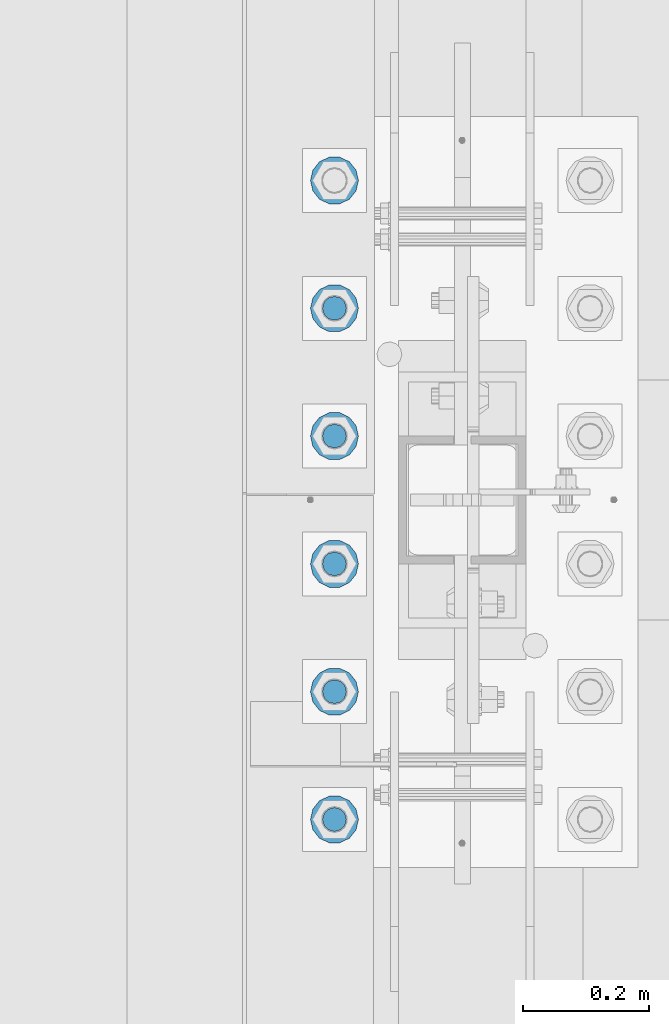
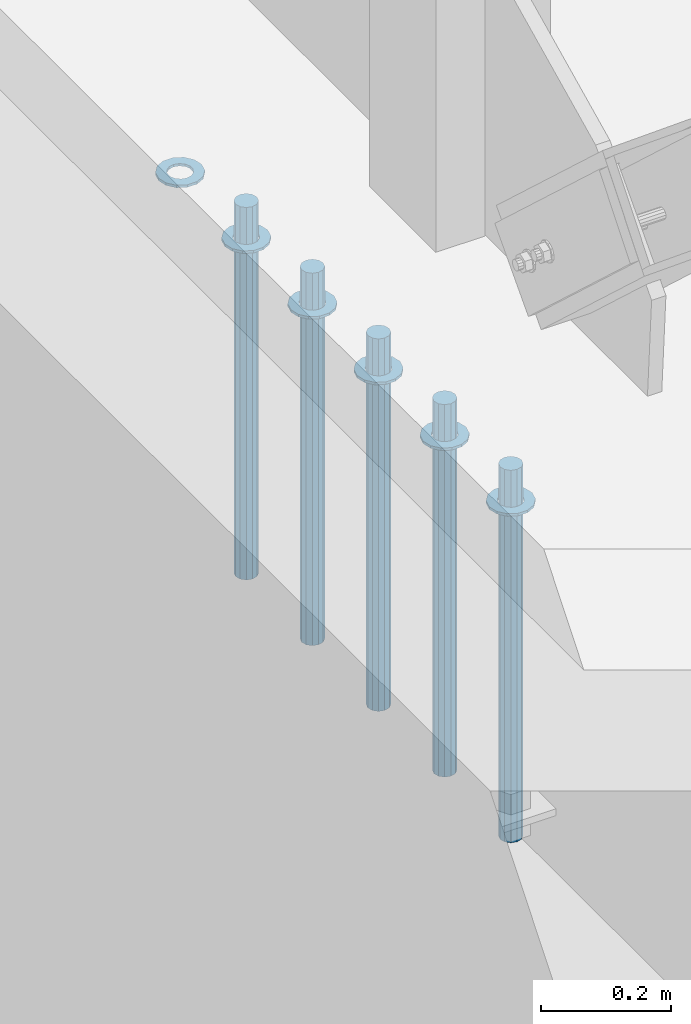
# One storey, part 923 of 1763: 11 columns, 1 element without a shape of its own.
"""IFC2X3 building model written with IfcOpenShell, lengths in millimetres."""

from ifc_helpers import new_model, si_unit, frame, origin_with_axes, place, context, subcontext, project, spatial, faceted_brep, material, type_object, element, aggregate, save


model = new_model("IFC2X3")

# Units and contexts
model_context = context("Model", 3, precision=1e-05, world=origin_with_axes())
body_context = subcontext(model_context, "Body", "Model", "MODEL_VIEW")
ifc_project = project(units=[si_unit("LENGTHUNIT", "METRE", prefix="MILLI"), si_unit("AREAUNIT", "SQUARE_METRE"), si_unit("VOLUMEUNIT", "CUBIC_METRE"), si_unit("MASSUNIT", "GRAM", prefix="KILO"), si_unit("TIMEUNIT", "SECOND"), si_unit("PLANEANGLEUNIT", "RADIAN"), si_unit("SOLIDANGLEUNIT", "STERADIAN"), si_unit("THERMODYNAMICTEMPERATUREUNIT", "DEGREE_CELSIUS"), si_unit("LUMINOUSINTENSITYUNIT", "LUMEN")], contexts=[model_context])

# Site, building, storey
site_placement = place(None, origin_with_axes())
site = spatial("IfcSite", under=ifc_project, at=site_placement, CompositionType="ELEMENT")
building_placement = place(site_placement, origin_with_axes())
building = spatial("IfcBuilding", under=site, at=building_placement, Name="Undefined", CompositionType="ELEMENT")
storey_placement = place(building_placement, origin_with_axes())
storey = spatial("IfcBuildingStorey", under=building, at=storey_placement, Name="Undefined", CompositionType="ELEMENT", Elevation=0.0)

# Assembly, columns
assembly_placement = place(storey_placement, origin_with_axes())
assembly = element("IfcElementAssembly", 1, at=assembly_placement, inside=storey, Name="TEMPLATE", AssemblyPlace="NOTDEFINED", PredefinedType="RIGID_FRAME")
ifc_material_1 = material(Name="STEEL/F436")
column_type_1 = type_object("IfcColumnType", Name="1-1/2_WASHER", PredefinedType="NOTDEFINED")
column_1_placement = place(assembly_placement, frame((-87578.6372736983, -50.7999999999992, 5151.4375), z_axis=(0.0, -1.0, 0.0), x_axis=(0.0, 0.0, -1.0)))
column_1 = element("IfcColumn", 2, at=column_1_placement, type_object=column_type_1, material=ifc_material_1, Name="WASHER", ObjectType="1-1/2_WASHER", context=body_context, shape_type="Brep", body=[
    faceted_brep([(0.0, -38.0999984741211, 0.0), (0.0, -34.3269124923099, -16.5309697983248), (4.76249999999982, -34.3269124923099, -16.5309697983248), (4.76249999999982, -38.0999984741211, 0.0), (0.0, -23.7549604994492, -29.7877782890519), (4.76249999999982, -23.7549604994492, -29.7877782890519), (0.0, -8.47804724419257, -37.1447519665053), (4.76249999999982, -8.47804724419257, -37.1447519665053), (0.0, 8.47804724419257, -37.1447519665053), (4.76249999999982, 8.47804724419257, -37.1447519665053), (0.0, 23.7549604994492, -29.7877782890519), (4.76249999999982, 23.7549604994492, -29.7877782890519), (0.0, 34.3269124923099, -16.5309697983248), (4.76249999999982, 34.3269124923099, -16.5309697983248), (0.0, 38.0999984741211, 0.0), (4.76249999999982, 38.0999984741211, 0.0), (0.0, 34.3269124923099, 16.5309697983248), (4.76249999999982, 34.3269124923099, 16.5309697983248), (0.0, 23.7549604994492, 29.7877782890519), (4.76249999999982, 23.7549604994492, 29.7877782890519), (0.0, 8.47804724419257, 37.1447519665053), (4.76249999999982, 8.47804724419257, 37.1447519665053), (0.0, -8.47804724419257, 37.1447519665053), (4.76249999999982, -8.47804724419257, 37.1447519665053), (0.0, -23.7549604994492, 29.7877782890519), (4.76249999999982, -23.7549604994492, 29.7877782890519), (0.0, -34.3269124923099, 16.5309697983248), (4.76249999999982, -34.3269124923099, 16.5309697983248), (0.0, 0.0, 20.6399993896484), (0.0, 8.95536011056538, 18.5959968835978), (4.76249999999982, 8.95536011056538, 18.5959968835978), (4.76249999999982, 0.0, 20.6399993896484), (0.0, 16.1370013209453, 12.8688291298167), (4.76249999999982, 16.1370013209453, 12.8688291298167), (0.0, 20.1225115123816, 4.59283194104137), (4.76249999999982, 20.1225115123816, 4.59283194104137), (0.0, 20.1225115123816, -4.59283194104319), (4.76249999999982, 20.1225115123816, -4.59283194104319), (0.0, 16.1370013209453, -12.8688291298167), (4.76249999999982, 16.1370013209453, -12.8688291298167), (0.0, 8.95536011056538, -18.5959968835978), (4.76249999999982, 8.95536011056538, -18.5959968835978), (0.0, 0.0, -20.6399993896484), (4.76249999999982, 0.0, -20.6399993896484), (0.0, -8.95536011056538, -18.5959968835978), (4.76249999999982, -8.95536011056538, -18.5959968835978), (0.0, -16.1370013209453, -12.8688291298167), (4.76249999999982, -16.1370013209453, -12.8688291298167), (0.0, -20.1225115123816, -4.59283194104137), (4.76249999999982, -20.1225115123816, -4.59283194104137), (0.0, -20.1225115123816, 4.59283194104319), (4.76249999999982, -20.1225115123816, 4.59283194104319), (0.0, -16.1370013209453, 12.8688291298167), (4.76249999999982, -16.1370013209453, 12.8688291298167), (0.0, -8.95536011056538, 18.5959968835978), (4.76249999999982, -8.95536011056538, 18.5959968835978)], [[[0, 1, 2, 3]], [[1, 4, 5, 2]], [[4, 6, 7, 5]], [[6, 8, 9, 7]], [[8, 10, 11, 9]], [[10, 12, 13, 11]], [[12, 14, 15, 13]], [[14, 16, 17, 15]], [[16, 18, 19, 17]], [[18, 20, 21, 19]], [[20, 22, 23, 21]], [[22, 24, 25, 23]], [[24, 26, 27, 25]], [[26, 0, 3, 27]], [[28, 29, 30, 31]], [[29, 32, 33, 30]], [[32, 34, 35, 33]], [[34, 36, 37, 35]], [[36, 38, 39, 37]], [[38, 40, 41, 39]], [[40, 42, 43, 41]], [[42, 44, 45, 43]], [[44, 46, 47, 45]], [[46, 48, 49, 47]], [[48, 50, 51, 49]], [[50, 52, 53, 51]], [[52, 54, 55, 53]], [[54, 28, 31, 55]], [[5, 7, 9, 11, 13, 15, 17, 19, 21, 23, 25, 27, 3, 2], [33, 35, 37, 39, 41, 43, 45, 47, 49, 51, 53, 55, 31, 30]], [[26, 24, 22, 20, 18, 16, 14, 12, 10, 8, 6, 4, 1, 0], [54, 52, 50, 48, 46, 44, 42, 40, 38, 36, 34, 32, 29, 28]]]),
])
column_2_placement = place(assembly_placement, frame((-87578.6372736983, 152.400000000001, 5151.4375), z_axis=(0.0, -1.0, 0.0), x_axis=(0.0, 0.0, -1.0)))
column_2 = element("IfcColumn", 3, at=column_2_placement, type_object=column_type_1, material=ifc_material_1, Name="WASHER", ObjectType="1-1/2_WASHER", context=body_context, shape_type="Brep", body=[
    faceted_brep([(0.0, -38.0999984741211, 0.0), (0.0, -34.3269124923099, -16.5309697983248), (4.76249999999982, -34.3269124923099, -16.5309697983248), (4.76249999999982, -38.0999984741211, 0.0), (0.0, -23.7549604994492, -29.7877782890519), (4.76249999999982, -23.7549604994492, -29.7877782890519), (0.0, -8.47804724419257, -37.1447519665053), (4.76249999999982, -8.47804724419257, -37.1447519665053), (0.0, 8.47804724419257, -37.1447519665053), (4.76249999999982, 8.47804724419257, -37.1447519665053), (0.0, 23.7549604994492, -29.7877782890519), (4.76249999999982, 23.7549604994492, -29.7877782890519), (0.0, 34.3269124923099, -16.5309697983248), (4.76249999999982, 34.3269124923099, -16.5309697983248), (0.0, 38.0999984741211, 0.0), (4.76249999999982, 38.0999984741211, 0.0), (0.0, 34.3269124923099, 16.5309697983248), (4.76249999999982, 34.3269124923099, 16.5309697983248), (0.0, 23.7549604994492, 29.7877782890519), (4.76249999999982, 23.7549604994492, 29.7877782890519), (0.0, 8.47804724419257, 37.1447519665053), (4.76249999999982, 8.47804724419257, 37.1447519665053), (0.0, -8.47804724419257, 37.1447519665053), (4.76249999999982, -8.47804724419257, 37.1447519665053), (0.0, -23.7549604994492, 29.7877782890519), (4.76249999999982, -23.7549604994492, 29.7877782890519), (0.0, -34.3269124923099, 16.5309697983248), (4.76249999999982, -34.3269124923099, 16.5309697983248), (0.0, 0.0, 20.6399993896484), (0.0, 8.95536011056538, 18.5959968835978), (4.76249999999982, 8.95536011056538, 18.5959968835978), (4.76249999999982, 0.0, 20.6399993896484), (0.0, 16.1370013209453, 12.8688291298167), (4.76249999999982, 16.1370013209453, 12.8688291298167), (0.0, 20.1225115123816, 4.59283194104137), (4.76249999999982, 20.1225115123816, 4.59283194104137), (0.0, 20.1225115123816, -4.59283194104319), (4.76249999999982, 20.1225115123816, -4.59283194104319), (0.0, 16.1370013209453, -12.8688291298167), (4.76249999999982, 16.1370013209453, -12.8688291298167), (0.0, 8.95536011056538, -18.5959968835978), (4.76249999999982, 8.95536011056538, -18.5959968835978), (0.0, 0.0, -20.6399993896484), (4.76249999999982, 0.0, -20.6399993896484), (0.0, -8.95536011056538, -18.5959968835978), (4.76249999999982, -8.95536011056538, -18.5959968835978), (0.0, -16.1370013209453, -12.8688291298167), (4.76249999999982, -16.1370013209453, -12.8688291298167), (0.0, -20.1225115123816, -4.59283194104137), (4.76249999999982, -20.1225115123816, -4.59283194104137), (0.0, -20.1225115123816, 4.59283194104319), (4.76249999999982, -20.1225115123816, 4.59283194104319), (0.0, -16.1370013209453, 12.8688291298167), (4.76249999999982, -16.1370013209453, 12.8688291298167), (0.0, -8.95536011056538, 18.5959968835978), (4.76249999999982, -8.95536011056538, 18.5959968835978)], [[[0, 1, 2, 3]], [[1, 4, 5, 2]], [[4, 6, 7, 5]], [[6, 8, 9, 7]], [[8, 10, 11, 9]], [[10, 12, 13, 11]], [[12, 14, 15, 13]], [[14, 16, 17, 15]], [[16, 18, 19, 17]], [[18, 20, 21, 19]], [[20, 22, 23, 21]], [[22, 24, 25, 23]], [[24, 26, 27, 25]], [[26, 0, 3, 27]], [[28, 29, 30, 31]], [[29, 32, 33, 30]], [[32, 34, 35, 33]], [[34, 36, 37, 35]], [[36, 38, 39, 37]], [[38, 40, 41, 39]], [[40, 42, 43, 41]], [[42, 44, 45, 43]], [[44, 46, 47, 45]], [[46, 48, 49, 47]], [[48, 50, 51, 49]], [[50, 52, 53, 51]], [[52, 54, 55, 53]], [[54, 28, 31, 55]], [[5, 7, 9, 11, 13, 15, 17, 19, 21, 23, 25, 27, 3, 2], [33, 35, 37, 39, 41, 43, 45, 47, 49, 51, 53, 55, 31, 30]], [[26, 24, 22, 20, 18, 16, 14, 12, 10, 8, 6, 4, 1, 0], [54, 52, 50, 48, 46, 44, 42, 40, 38, 36, 34, 32, 29, 28]]]),
])
column_3_placement = place(assembly_placement, frame((-87578.6372736983, 355.600000000001, 5151.4375), z_axis=(0.0, -1.0, 0.0), x_axis=(0.0, 0.0, -1.0)))
column_3 = element("IfcColumn", 4, at=column_3_placement, type_object=column_type_1, material=ifc_material_1, Name="WASHER", ObjectType="1-1/2_WASHER", context=body_context, shape_type="Brep", body=[
    faceted_brep([(0.0, -38.0999984741211, 0.0), (0.0, -34.3269124923099, -16.5309697983248), (4.76249999999982, -34.3269124923099, -16.5309697983248), (4.76249999999982, -38.0999984741211, 0.0), (0.0, -23.7549604994492, -29.7877782890519), (4.76249999999982, -23.7549604994492, -29.7877782890519), (0.0, -8.47804724419257, -37.1447519665053), (4.76249999999982, -8.47804724419257, -37.1447519665053), (0.0, 8.47804724419257, -37.1447519665053), (4.76249999999982, 8.47804724419257, -37.1447519665053), (0.0, 23.7549604994492, -29.7877782890519), (4.76249999999982, 23.7549604994492, -29.7877782890519), (0.0, 34.3269124923099, -16.5309697983248), (4.76249999999982, 34.3269124923099, -16.5309697983248), (0.0, 38.0999984741211, 0.0), (4.76249999999982, 38.0999984741211, 0.0), (0.0, 34.3269124923099, 16.5309697983248), (4.76249999999982, 34.3269124923099, 16.5309697983248), (0.0, 23.7549604994492, 29.7877782890519), (4.76249999999982, 23.7549604994492, 29.7877782890519), (0.0, 8.47804724419257, 37.1447519665053), (4.76249999999982, 8.47804724419257, 37.1447519665053), (0.0, -8.47804724419257, 37.1447519665053), (4.76249999999982, -8.47804724419257, 37.1447519665053), (0.0, -23.7549604994492, 29.7877782890519), (4.76249999999982, -23.7549604994492, 29.7877782890519), (0.0, -34.3269124923099, 16.5309697983248), (4.76249999999982, -34.3269124923099, 16.5309697983248), (0.0, 0.0, 20.6399993896484), (0.0, 8.95536011056538, 18.5959968835978), (4.76249999999982, 8.95536011056538, 18.5959968835978), (4.76249999999982, 0.0, 20.6399993896484), (0.0, 16.1370013209453, 12.8688291298167), (4.76249999999982, 16.1370013209453, 12.8688291298167), (0.0, 20.1225115123816, 4.59283194104137), (4.76249999999982, 20.1225115123816, 4.59283194104137), (0.0, 20.1225115123816, -4.59283194104319), (4.76249999999982, 20.1225115123816, -4.59283194104319), (0.0, 16.1370013209453, -12.8688291298167), (4.76249999999982, 16.1370013209453, -12.8688291298167), (0.0, 8.95536011056538, -18.5959968835978), (4.76249999999982, 8.95536011056538, -18.5959968835978), (0.0, 0.0, -20.6399993896484), (4.76249999999982, 0.0, -20.6399993896484), (0.0, -8.95536011056538, -18.5959968835978), (4.76249999999982, -8.95536011056538, -18.5959968835978), (0.0, -16.1370013209453, -12.8688291298167), (4.76249999999982, -16.1370013209453, -12.8688291298167), (0.0, -20.1225115123816, -4.59283194104137), (4.76249999999982, -20.1225115123816, -4.59283194104137), (0.0, -20.1225115123816, 4.59283194104319), (4.76249999999982, -20.1225115123816, 4.59283194104319), (0.0, -16.1370013209453, 12.8688291298167), (4.76249999999982, -16.1370013209453, 12.8688291298167), (0.0, -8.95536011056538, 18.5959968835978), (4.76249999999982, -8.95536011056538, 18.5959968835978)], [[[0, 1, 2, 3]], [[1, 4, 5, 2]], [[4, 6, 7, 5]], [[6, 8, 9, 7]], [[8, 10, 11, 9]], [[10, 12, 13, 11]], [[12, 14, 15, 13]], [[14, 16, 17, 15]], [[16, 18, 19, 17]], [[18, 20, 21, 19]], [[20, 22, 23, 21]], [[22, 24, 25, 23]], [[24, 26, 27, 25]], [[26, 0, 3, 27]], [[28, 29, 30, 31]], [[29, 32, 33, 30]], [[32, 34, 35, 33]], [[34, 36, 37, 35]], [[36, 38, 39, 37]], [[38, 40, 41, 39]], [[40, 42, 43, 41]], [[42, 44, 45, 43]], [[44, 46, 47, 45]], [[46, 48, 49, 47]], [[48, 50, 51, 49]], [[50, 52, 53, 51]], [[52, 54, 55, 53]], [[54, 28, 31, 55]], [[5, 7, 9, 11, 13, 15, 17, 19, 21, 23, 25, 27, 3, 2], [33, 35, 37, 39, 41, 43, 45, 47, 49, 51, 53, 55, 31, 30]], [[26, 24, 22, 20, 18, 16, 14, 12, 10, 8, 6, 4, 1, 0], [54, 52, 50, 48, 46, 44, 42, 40, 38, 36, 34, 32, 29, 28]]]),
])
column_4_placement = place(assembly_placement, frame((-87578.6372736983, 558.800000000001, 5151.4375), z_axis=(0.0, -1.0, 0.0), x_axis=(0.0, 0.0, -1.0)))
column_4 = element("IfcColumn", 5, at=column_4_placement, type_object=column_type_1, material=ifc_material_1, Name="WASHER", ObjectType="1-1/2_WASHER", context=body_context, shape_type="Brep", body=[
    faceted_brep([(0.0, -38.0999984741211, 0.0), (0.0, -34.3269124923099, -16.5309697983248), (4.76249999999982, -34.3269124923099, -16.5309697983248), (4.76249999999982, -38.0999984741211, 0.0), (0.0, -23.7549604994492, -29.7877782890519), (4.76249999999982, -23.7549604994492, -29.7877782890519), (0.0, -8.47804724419257, -37.1447519665053), (4.76249999999982, -8.47804724419257, -37.1447519665053), (0.0, 8.47804724419257, -37.1447519665053), (4.76249999999982, 8.47804724419257, -37.1447519665053), (0.0, 23.7549604994492, -29.7877782890519), (4.76249999999982, 23.7549604994492, -29.7877782890519), (0.0, 34.3269124923099, -16.5309697983248), (4.76249999999982, 34.3269124923099, -16.5309697983248), (0.0, 38.0999984741211, 0.0), (4.76249999999982, 38.0999984741211, 0.0), (0.0, 34.3269124923099, 16.5309697983248), (4.76249999999982, 34.3269124923099, 16.5309697983248), (0.0, 23.7549604994492, 29.7877782890519), (4.76249999999982, 23.7549604994492, 29.7877782890519), (0.0, 8.47804724419257, 37.1447519665053), (4.76249999999982, 8.47804724419257, 37.1447519665053), (0.0, -8.47804724419257, 37.1447519665053), (4.76249999999982, -8.47804724419257, 37.1447519665053), (0.0, -23.7549604994492, 29.7877782890519), (4.76249999999982, -23.7549604994492, 29.7877782890519), (0.0, -34.3269124923099, 16.5309697983248), (4.76249999999982, -34.3269124923099, 16.5309697983248), (0.0, 0.0, 20.6399993896484), (0.0, 8.95536011056538, 18.5959968835978), (4.76249999999982, 8.95536011056538, 18.5959968835978), (4.76249999999982, 0.0, 20.6399993896484), (0.0, 16.1370013209453, 12.8688291298167), (4.76249999999982, 16.1370013209453, 12.8688291298167), (0.0, 20.1225115123816, 4.59283194104137), (4.76249999999982, 20.1225115123816, 4.59283194104137), (0.0, 20.1225115123816, -4.59283194104319), (4.76249999999982, 20.1225115123816, -4.59283194104319), (0.0, 16.1370013209453, -12.8688291298167), (4.76249999999982, 16.1370013209453, -12.8688291298167), (0.0, 8.95536011056538, -18.5959968835978), (4.76249999999982, 8.95536011056538, -18.5959968835978), (0.0, 0.0, -20.6399993896484), (4.76249999999982, 0.0, -20.6399993896484), (0.0, -8.95536011056538, -18.5959968835978), (4.76249999999982, -8.95536011056538, -18.5959968835978), (0.0, -16.1370013209453, -12.8688291298167), (4.76249999999982, -16.1370013209453, -12.8688291298167), (0.0, -20.1225115123816, -4.59283194104137), (4.76249999999982, -20.1225115123816, -4.59283194104137), (0.0, -20.1225115123816, 4.59283194104319), (4.76249999999982, -20.1225115123816, 4.59283194104319), (0.0, -16.1370013209453, 12.8688291298167), (4.76249999999982, -16.1370013209453, 12.8688291298167), (0.0, -8.95536011056538, 18.5959968835978), (4.76249999999982, -8.95536011056538, 18.5959968835978)], [[[0, 1, 2, 3]], [[1, 4, 5, 2]], [[4, 6, 7, 5]], [[6, 8, 9, 7]], [[8, 10, 11, 9]], [[10, 12, 13, 11]], [[12, 14, 15, 13]], [[14, 16, 17, 15]], [[16, 18, 19, 17]], [[18, 20, 21, 19]], [[20, 22, 23, 21]], [[22, 24, 25, 23]], [[24, 26, 27, 25]], [[26, 0, 3, 27]], [[28, 29, 30, 31]], [[29, 32, 33, 30]], [[32, 34, 35, 33]], [[34, 36, 37, 35]], [[36, 38, 39, 37]], [[38, 40, 41, 39]], [[40, 42, 43, 41]], [[42, 44, 45, 43]], [[44, 46, 47, 45]], [[46, 48, 49, 47]], [[48, 50, 51, 49]], [[50, 52, 53, 51]], [[52, 54, 55, 53]], [[54, 28, 31, 55]], [[5, 7, 9, 11, 13, 15, 17, 19, 21, 23, 25, 27, 3, 2], [33, 35, 37, 39, 41, 43, 45, 47, 49, 51, 53, 55, 31, 30]], [[26, 24, 22, 20, 18, 16, 14, 12, 10, 8, 6, 4, 1, 0], [54, 52, 50, 48, 46, 44, 42, 40, 38, 36, 34, 32, 29, 28]]]),
])
column_5_placement = place(assembly_placement, frame((-87578.6372736983, 762.000000000001, 5151.4375), z_axis=(0.0, -1.0, 0.0), x_axis=(0.0, 0.0, -1.0)))
column_5 = element("IfcColumn", 6, at=column_5_placement, type_object=column_type_1, material=ifc_material_1, Name="WASHER", ObjectType="1-1/2_WASHER", context=body_context, shape_type="Brep", body=[
    faceted_brep([(0.0, -38.0999984741211, 0.0), (0.0, -34.3269124923099, -16.5309697983248), (4.76249999999982, -34.3269124923099, -16.5309697983248), (4.76249999999982, -38.0999984741211, 0.0), (0.0, -23.7549604994492, -29.7877782890519), (4.76249999999982, -23.7549604994492, -29.7877782890519), (0.0, -8.47804724419257, -37.1447519665053), (4.76249999999982, -8.47804724419257, -37.1447519665053), (0.0, 8.47804724419257, -37.1447519665053), (4.76249999999982, 8.47804724419257, -37.1447519665053), (0.0, 23.7549604994492, -29.7877782890519), (4.76249999999982, 23.7549604994492, -29.7877782890519), (0.0, 34.3269124923099, -16.5309697983248), (4.76249999999982, 34.3269124923099, -16.5309697983248), (0.0, 38.0999984741211, 0.0), (4.76249999999982, 38.0999984741211, 0.0), (0.0, 34.3269124923099, 16.5309697983248), (4.76249999999982, 34.3269124923099, 16.5309697983248), (0.0, 23.7549604994492, 29.7877782890519), (4.76249999999982, 23.7549604994492, 29.7877782890519), (0.0, 8.47804724419257, 37.1447519665053), (4.76249999999982, 8.47804724419257, 37.1447519665053), (0.0, -8.47804724419257, 37.1447519665053), (4.76249999999982, -8.47804724419257, 37.1447519665053), (0.0, -23.7549604994492, 29.7877782890519), (4.76249999999982, -23.7549604994492, 29.7877782890519), (0.0, -34.3269124923099, 16.5309697983248), (4.76249999999982, -34.3269124923099, 16.5309697983248), (0.0, 0.0, 20.6399993896484), (0.0, 8.95536011056538, 18.5959968835978), (4.76249999999982, 8.95536011056538, 18.5959968835978), (4.76249999999982, 0.0, 20.6399993896484), (0.0, 16.1370013209453, 12.8688291298167), (4.76249999999982, 16.1370013209453, 12.8688291298167), (0.0, 20.1225115123816, 4.59283194104137), (4.76249999999982, 20.1225115123816, 4.59283194104137), (0.0, 20.1225115123816, -4.59283194104319), (4.76249999999982, 20.1225115123816, -4.59283194104319), (0.0, 16.1370013209453, -12.8688291298167), (4.76249999999982, 16.1370013209453, -12.8688291298167), (0.0, 8.95536011056538, -18.5959968835978), (4.76249999999982, 8.95536011056538, -18.5959968835978), (0.0, 0.0, -20.6399993896484), (4.76249999999982, 0.0, -20.6399993896484), (0.0, -8.95536011056538, -18.5959968835978), (4.76249999999982, -8.95536011056538, -18.5959968835978), (0.0, -16.1370013209453, -12.8688291298167), (4.76249999999982, -16.1370013209453, -12.8688291298167), (0.0, -20.1225115123816, -4.59283194104137), (4.76249999999982, -20.1225115123816, -4.59283194104137), (0.0, -20.1225115123816, 4.59283194104319), (4.76249999999982, -20.1225115123816, 4.59283194104319), (0.0, -16.1370013209453, 12.8688291298167), (4.76249999999982, -16.1370013209453, 12.8688291298167), (0.0, -8.95536011056538, 18.5959968835978), (4.76249999999982, -8.95536011056538, 18.5959968835978)], [[[0, 1, 2, 3]], [[1, 4, 5, 2]], [[4, 6, 7, 5]], [[6, 8, 9, 7]], [[8, 10, 11, 9]], [[10, 12, 13, 11]], [[12, 14, 15, 13]], [[14, 16, 17, 15]], [[16, 18, 19, 17]], [[18, 20, 21, 19]], [[20, 22, 23, 21]], [[22, 24, 25, 23]], [[24, 26, 27, 25]], [[26, 0, 3, 27]], [[28, 29, 30, 31]], [[29, 32, 33, 30]], [[32, 34, 35, 33]], [[34, 36, 37, 35]], [[36, 38, 39, 37]], [[38, 40, 41, 39]], [[40, 42, 43, 41]], [[42, 44, 45, 43]], [[44, 46, 47, 45]], [[46, 48, 49, 47]], [[48, 50, 51, 49]], [[50, 52, 53, 51]], [[52, 54, 55, 53]], [[54, 28, 31, 55]], [[5, 7, 9, 11, 13, 15, 17, 19, 21, 23, 25, 27, 3, 2], [33, 35, 37, 39, 41, 43, 45, 47, 49, 51, 53, 55, 31, 30]], [[26, 24, 22, 20, 18, 16, 14, 12, 10, 8, 6, 4, 1, 0], [54, 52, 50, 48, 46, 44, 42, 40, 38, 36, 34, 32, 29, 28]]]),
])
column_6_placement = place(assembly_placement, frame((-87578.6372736983, 965.200000000001, 5151.4375), z_axis=(0.0, -1.0, 0.0), x_axis=(0.0, 0.0, -1.0)))
column_6 = element("IfcColumn", 7, at=column_6_placement, type_object=column_type_1, material=ifc_material_1, Name="WASHER", ObjectType="1-1/2_WASHER", context=body_context, shape_type="Brep", body=[
    faceted_brep([(0.0, -38.0999984741211, 0.0), (0.0, -34.3269124923099, -16.5309697983248), (4.76249999999982, -34.3269124923099, -16.5309697983248), (4.76249999999982, -38.0999984741211, 0.0), (0.0, -23.7549604994492, -29.7877782890519), (4.76249999999982, -23.7549604994492, -29.7877782890519), (0.0, -8.47804724419257, -37.1447519665053), (4.76249999999982, -8.47804724419257, -37.1447519665053), (0.0, 8.47804724419257, -37.1447519665053), (4.76249999999982, 8.47804724419257, -37.1447519665053), (0.0, 23.7549604994492, -29.7877782890519), (4.76249999999982, 23.7549604994492, -29.7877782890519), (0.0, 34.3269124923099, -16.5309697983248), (4.76249999999982, 34.3269124923099, -16.5309697983248), (0.0, 38.0999984741211, 0.0), (4.76249999999982, 38.0999984741211, 0.0), (0.0, 34.3269124923099, 16.5309697983248), (4.76249999999982, 34.3269124923099, 16.5309697983248), (0.0, 23.7549604994492, 29.7877782890519), (4.76249999999982, 23.7549604994492, 29.7877782890519), (0.0, 8.47804724419257, 37.1447519665053), (4.76249999999982, 8.47804724419257, 37.1447519665053), (0.0, -8.47804724419257, 37.1447519665053), (4.76249999999982, -8.47804724419257, 37.1447519665053), (0.0, -23.7549604994492, 29.7877782890519), (4.76249999999982, -23.7549604994492, 29.7877782890519), (0.0, -34.3269124923099, 16.5309697983248), (4.76249999999982, -34.3269124923099, 16.5309697983248), (0.0, 0.0, 20.6399993896484), (0.0, 8.95536011056538, 18.5959968835978), (4.76249999999982, 8.95536011056538, 18.5959968835978), (4.76249999999982, 0.0, 20.6399993896484), (0.0, 16.1370013209453, 12.8688291298167), (4.76249999999982, 16.1370013209453, 12.8688291298167), (0.0, 20.1225115123816, 4.59283194104137), (4.76249999999982, 20.1225115123816, 4.59283194104137), (0.0, 20.1225115123816, -4.59283194104319), (4.76249999999982, 20.1225115123816, -4.59283194104319), (0.0, 16.1370013209453, -12.8688291298167), (4.76249999999982, 16.1370013209453, -12.8688291298167), (0.0, 8.95536011056538, -18.5959968835978), (4.76249999999982, 8.95536011056538, -18.5959968835978), (0.0, 0.0, -20.6399993896484), (4.76249999999982, 0.0, -20.6399993896484), (0.0, -8.95536011056538, -18.5959968835978), (4.76249999999982, -8.95536011056538, -18.5959968835978), (0.0, -16.1370013209453, -12.8688291298167), (4.76249999999982, -16.1370013209453, -12.8688291298167), (0.0, -20.1225115123816, -4.59283194104137), (4.76249999999982, -20.1225115123816, -4.59283194104137), (0.0, -20.1225115123816, 4.59283194104319), (4.76249999999982, -20.1225115123816, 4.59283194104319), (0.0, -16.1370013209453, 12.8688291298167), (4.76249999999982, -16.1370013209453, 12.8688291298167), (0.0, -8.95536011056538, 18.5959968835978), (4.76249999999982, -8.95536011056538, 18.5959968835978)], [[[0, 1, 2, 3]], [[1, 4, 5, 2]], [[4, 6, 7, 5]], [[6, 8, 9, 7]], [[8, 10, 11, 9]], [[10, 12, 13, 11]], [[12, 14, 15, 13]], [[14, 16, 17, 15]], [[16, 18, 19, 17]], [[18, 20, 21, 19]], [[20, 22, 23, 21]], [[22, 24, 25, 23]], [[24, 26, 27, 25]], [[26, 0, 3, 27]], [[28, 29, 30, 31]], [[29, 32, 33, 30]], [[32, 34, 35, 33]], [[34, 36, 37, 35]], [[36, 38, 39, 37]], [[38, 40, 41, 39]], [[40, 42, 43, 41]], [[42, 44, 45, 43]], [[44, 46, 47, 45]], [[46, 48, 49, 47]], [[48, 50, 51, 49]], [[50, 52, 53, 51]], [[52, 54, 55, 53]], [[54, 28, 31, 55]], [[5, 7, 9, 11, 13, 15, 17, 19, 21, 23, 25, 27, 3, 2], [33, 35, 37, 39, 41, 43, 45, 47, 49, 51, 53, 55, 31, 30]], [[26, 24, 22, 20, 18, 16, 14, 12, 10, 8, 6, 4, 1, 0], [54, 52, 50, 48, 46, 44, 42, 40, 38, 36, 34, 32, 29, 28]]]),
])
ifc_material_2 = material(Name="STEEL/F1554-GR.55")
column_type_2 = type_object("IfcColumnType", PredefinedType="NOTDEFINED")
column_7_placement = place(assembly_placement, frame((-87578.6372736983, -50.7999999999992, 5219.7), z_axis=(0.0, -1.0, 0.0), x_axis=(0.0, 0.0, -1.0)))
column_7 = element("IfcColumn", 8, at=column_7_placement, type_object=column_type_2, material=ifc_material_2, Name="ALL THREADED ROD", context=body_context, shape_type="Brep", body=[
    faceted_brep([(0.0, -19.0500000000029, 0.0), (0.0, -16.4977839420899, -9.52500000000146), (698.499, -16.4977839420972, -9.52499999999964), (698.499, -19.0500000000029, 0.0), (0.0, -9.52499999999418, -16.4977839420935), (698.499, -9.52500000000146, -16.4977839420935), (1.45519152283669e-11, 1.81898940354586e-12, -19.0499999999993), (698.499, 0.0, -19.0499999999993), (0.0, 9.52499999999418, -16.4977839420935), (698.499, 9.52500000000146, -16.4977839420935), (0.0, 16.4977839420899, -9.52500000000146), (698.499, 16.4977839420972, -9.52499999999964), (0.0, 19.0500000000029, 0.0), (698.499, 19.0500000000029, 0.0), (0.0, 16.4977839420899, 9.52500000000146), (698.499, 16.4977839420972, 9.52499999999964), (0.0, 9.52499999999418, 16.4977839420935), (698.499, 9.52500000000146, 16.4977839420935), (1.45519152283669e-11, 1.81898940354586e-12, 19.0499999999993), (698.499, 0.0, 19.0499999999993), (0.0, -9.52499999999418, 16.4977839420935), (698.499, -9.52500000000146, 16.4977839420935), (0.0, -16.4977839420899, 9.52500000000146), (698.499, -16.4977839420972, 9.52499999999964)], [[[0, 1, 2, 3]], [[1, 4, 5, 2]], [[4, 6, 7, 5]], [[6, 8, 9, 7]], [[8, 10, 11, 9]], [[10, 12, 13, 11]], [[12, 14, 15, 13]], [[14, 16, 17, 15]], [[16, 18, 19, 17]], [[18, 20, 21, 19]], [[20, 22, 23, 21]], [[22, 0, 3, 23]], [[5, 7, 9, 11, 13, 15, 17, 19, 21, 23, 3, 2]], [[22, 20, 18, 16, 14, 12, 10, 8, 6, 4, 1, 0]]]),
])
column_8_placement = place(assembly_placement, frame((-87578.6372736983, 152.400000000001, 5219.7), z_axis=(0.0, -1.0, 0.0), x_axis=(0.0, 0.0, -1.0)))
column_8 = element("IfcColumn", 9, at=column_8_placement, type_object=column_type_2, material=ifc_material_2, Name="ALL THREADED ROD", context=body_context, shape_type="Brep", body=[
    faceted_brep([(0.0, -19.0500000000029, 0.0), (0.0, -16.4977839420899, -9.52500000000146), (698.499, -16.4977839420972, -9.52499999999964), (698.499, -19.0500000000029, 0.0), (0.0, -9.52499999999418, -16.4977839420935), (698.499, -9.52500000000146, -16.4977839420935), (1.45519152283669e-11, 1.81898940354586e-12, -19.0499999999993), (698.499, 0.0, -19.0499999999993), (0.0, 9.52499999999418, -16.4977839420935), (698.499, 9.52500000000146, -16.4977839420935), (0.0, 16.4977839420899, -9.52500000000146), (698.499, 16.4977839420972, -9.52499999999964), (0.0, 19.0500000000029, 0.0), (698.499, 19.0500000000029, 0.0), (0.0, 16.4977839420899, 9.52500000000146), (698.499, 16.4977839420972, 9.52499999999964), (0.0, 9.52499999999418, 16.4977839420935), (698.499, 9.52500000000146, 16.4977839420935), (1.45519152283669e-11, 1.81898940354586e-12, 19.0499999999993), (698.499, 0.0, 19.0499999999993), (0.0, -9.52499999999418, 16.4977839420935), (698.499, -9.52500000000146, 16.4977839420935), (0.0, -16.4977839420899, 9.52500000000146), (698.499, -16.4977839420972, 9.52499999999964)], [[[0, 1, 2, 3]], [[1, 4, 5, 2]], [[4, 6, 7, 5]], [[6, 8, 9, 7]], [[8, 10, 11, 9]], [[10, 12, 13, 11]], [[12, 14, 15, 13]], [[14, 16, 17, 15]], [[16, 18, 19, 17]], [[18, 20, 21, 19]], [[20, 22, 23, 21]], [[22, 0, 3, 23]], [[5, 7, 9, 11, 13, 15, 17, 19, 21, 23, 3, 2]], [[22, 20, 18, 16, 14, 12, 10, 8, 6, 4, 1, 0]]]),
])
column_9_placement = place(assembly_placement, frame((-87578.6372736983, 355.600000000001, 5219.7), z_axis=(0.0, -1.0, 0.0), x_axis=(0.0, 0.0, -1.0)))
column_9 = element("IfcColumn", 10, at=column_9_placement, type_object=column_type_2, material=ifc_material_2, Name="ALL THREADED ROD", context=body_context, shape_type="Brep", body=[
    faceted_brep([(0.0, -19.0500000000029, 0.0), (0.0, -16.4977839420899, -9.52500000000146), (698.499, -16.4977839420972, -9.52499999999964), (698.499, -19.0500000000029, 0.0), (0.0, -9.52499999999418, -16.4977839420935), (698.499, -9.52500000000146, -16.4977839420935), (1.45519152283669e-11, 1.81898940354586e-12, -19.0499999999993), (698.499, 0.0, -19.0499999999993), (0.0, 9.52499999999418, -16.4977839420935), (698.499, 9.52500000000146, -16.4977839420935), (0.0, 16.4977839420899, -9.52500000000146), (698.499, 16.4977839420972, -9.52499999999964), (0.0, 19.0500000000029, 0.0), (698.499, 19.0500000000029, 0.0), (0.0, 16.4977839420899, 9.52500000000146), (698.499, 16.4977839420972, 9.52499999999964), (0.0, 9.52499999999418, 16.4977839420935), (698.499, 9.52500000000146, 16.4977839420935), (1.45519152283669e-11, 1.81898940354586e-12, 19.0499999999993), (698.499, 0.0, 19.0499999999993), (0.0, -9.52499999999418, 16.4977839420935), (698.499, -9.52500000000146, 16.4977839420935), (0.0, -16.4977839420899, 9.52500000000146), (698.499, -16.4977839420972, 9.52499999999964)], [[[0, 1, 2, 3]], [[1, 4, 5, 2]], [[4, 6, 7, 5]], [[6, 8, 9, 7]], [[8, 10, 11, 9]], [[10, 12, 13, 11]], [[12, 14, 15, 13]], [[14, 16, 17, 15]], [[16, 18, 19, 17]], [[18, 20, 21, 19]], [[20, 22, 23, 21]], [[22, 0, 3, 23]], [[5, 7, 9, 11, 13, 15, 17, 19, 21, 23, 3, 2]], [[22, 20, 18, 16, 14, 12, 10, 8, 6, 4, 1, 0]]]),
])
column_10_placement = place(assembly_placement, frame((-87578.6372736983, 558.800000000001, 5219.7), z_axis=(0.0, -1.0, 0.0), x_axis=(0.0, 0.0, -1.0)))
column_10 = element("IfcColumn", 11, at=column_10_placement, type_object=column_type_2, material=ifc_material_2, Name="ALL THREADED ROD", context=body_context, shape_type="Brep", body=[
    faceted_brep([(0.0, -19.0500000000029, 0.0), (0.0, -16.4977839420899, -9.52500000000146), (698.499, -16.4977839420972, -9.52499999999964), (698.499, -19.0500000000029, 0.0), (0.0, -9.52499999999418, -16.4977839420935), (698.499, -9.52500000000146, -16.4977839420935), (1.45519152283669e-11, 1.81898940354586e-12, -19.0499999999993), (698.499, 0.0, -19.0499999999993), (0.0, 9.52499999999418, -16.4977839420935), (698.499, 9.52500000000146, -16.4977839420935), (0.0, 16.4977839420899, -9.52500000000146), (698.499, 16.4977839420972, -9.52499999999964), (0.0, 19.0500000000029, 0.0), (698.499, 19.0500000000029, 0.0), (0.0, 16.4977839420899, 9.52500000000146), (698.499, 16.4977839420972, 9.52499999999964), (0.0, 9.52499999999418, 16.4977839420935), (698.499, 9.52500000000146, 16.4977839420935), (1.45519152283669e-11, 1.81898940354586e-12, 19.0499999999993), (698.499, 0.0, 19.0499999999993), (0.0, -9.52499999999418, 16.4977839420935), (698.499, -9.52500000000146, 16.4977839420935), (0.0, -16.4977839420899, 9.52500000000146), (698.499, -16.4977839420972, 9.52499999999964)], [[[0, 1, 2, 3]], [[1, 4, 5, 2]], [[4, 6, 7, 5]], [[6, 8, 9, 7]], [[8, 10, 11, 9]], [[10, 12, 13, 11]], [[12, 14, 15, 13]], [[14, 16, 17, 15]], [[16, 18, 19, 17]], [[18, 20, 21, 19]], [[20, 22, 23, 21]], [[22, 0, 3, 23]], [[5, 7, 9, 11, 13, 15, 17, 19, 21, 23, 3, 2]], [[22, 20, 18, 16, 14, 12, 10, 8, 6, 4, 1, 0]]]),
])
column_11_placement = place(assembly_placement, frame((-87578.6372736983, 762.000000000001, 5219.7), z_axis=(0.0, -1.0, 0.0), x_axis=(0.0, 0.0, -1.0)))
column_11 = element("IfcColumn", 12, at=column_11_placement, type_object=column_type_2, material=ifc_material_2, Name="ALL THREADED ROD", context=body_context, shape_type="Brep", body=[
    faceted_brep([(0.0, -19.0500000000029, 0.0), (0.0, -16.4977839420899, -9.52500000000146), (698.499, -16.4977839420972, -9.52499999999964), (698.499, -19.0500000000029, 0.0), (0.0, -9.52499999999418, -16.4977839420935), (698.499, -9.52500000000146, -16.4977839420935), (1.45519152283669e-11, 1.81898940354586e-12, -19.0499999999993), (698.499, 0.0, -19.0499999999993), (0.0, 9.52499999999418, -16.4977839420935), (698.499, 9.52500000000146, -16.4977839420935), (0.0, 16.4977839420899, -9.52500000000146), (698.499, 16.4977839420972, -9.52499999999964), (0.0, 19.0500000000029, 0.0), (698.499, 19.0500000000029, 0.0), (0.0, 16.4977839420899, 9.52500000000146), (698.499, 16.4977839420972, 9.52499999999964), (0.0, 9.52499999999418, 16.4977839420935), (698.499, 9.52500000000146, 16.4977839420935), (1.45519152283669e-11, 1.81898940354586e-12, 19.0499999999993), (698.499, 0.0, 19.0499999999993), (0.0, -9.52499999999418, 16.4977839420935), (698.499, -9.52500000000146, 16.4977839420935), (0.0, -16.4977839420899, 9.52500000000146), (698.499, -16.4977839420972, 9.52499999999964)], [[[0, 1, 2, 3]], [[1, 4, 5, 2]], [[4, 6, 7, 5]], [[6, 8, 9, 7]], [[8, 10, 11, 9]], [[10, 12, 13, 11]], [[12, 14, 15, 13]], [[14, 16, 17, 15]], [[16, 18, 19, 17]], [[18, 20, 21, 19]], [[20, 22, 23, 21]], [[22, 0, 3, 23]], [[5, 7, 9, 11, 13, 15, 17, 19, 21, 23, 3, 2]], [[22, 20, 18, 16, 14, 12, 10, 8, 6, 4, 1, 0]]]),
])
aggregate(assembly, [column_1, column_7, column_2, column_8, column_3, column_9, column_4, column_10, column_5, column_11, column_6])

save(model, "model.ifc")
